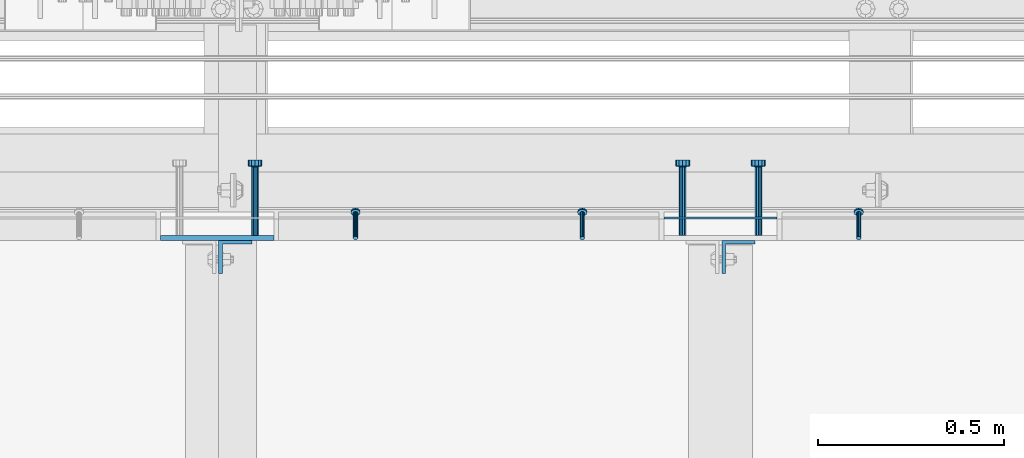
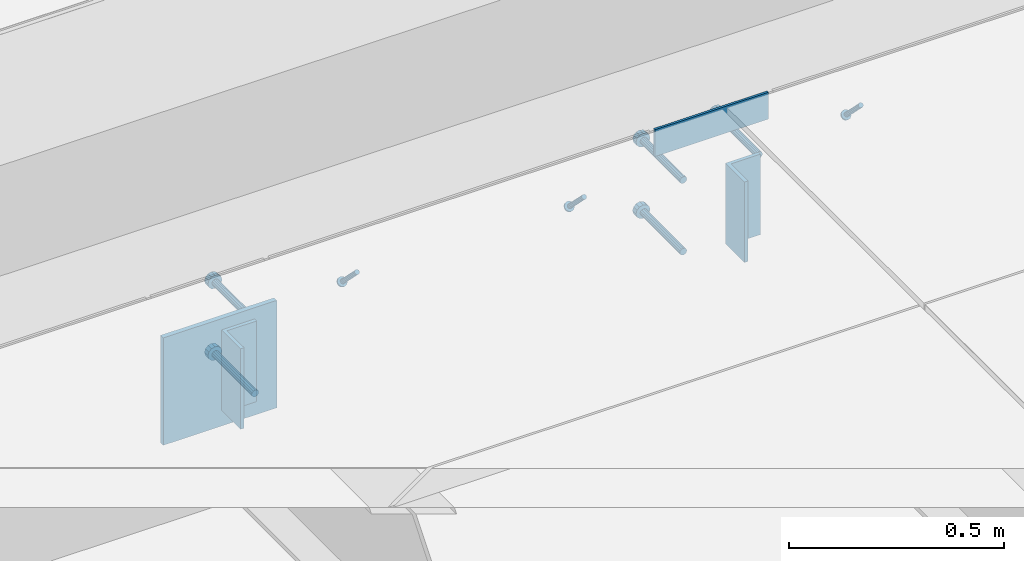
# One storey, part 2100 of 3843: 9 beams, 3 members, 6 elements without a shape of their own.
"""IFC2X3 building model written with IfcOpenShell, lengths in millimetres."""

from ifc_helpers import new_model, si_unit, frame, origin_with_axes, place, context, subcontext, project, spatial, faceted_brep, material, type_object, element, aggregate, save


model = new_model("IFC2X3")

# Units and contexts
model_context = context("Model", 3, precision=1e-05, world=origin_with_axes())
body_context = subcontext(model_context, "Body", "Model", "MODEL_VIEW")
ifc_project = project(units=[si_unit("LENGTHUNIT", "METRE", prefix="MILLI"), si_unit("AREAUNIT", "SQUARE_METRE"), si_unit("VOLUMEUNIT", "CUBIC_METRE"), si_unit("MASSUNIT", "GRAM", prefix="KILO"), si_unit("TIMEUNIT", "SECOND"), si_unit("PLANEANGLEUNIT", "RADIAN"), si_unit("SOLIDANGLEUNIT", "STERADIAN"), si_unit("THERMODYNAMICTEMPERATUREUNIT", "DEGREE_CELSIUS"), si_unit("LUMINOUSINTENSITYUNIT", "LUMEN")], contexts=[model_context])

# Site, building, storey
site_placement = place(None, origin_with_axes())
site = spatial("IfcSite", under=ifc_project, at=site_placement, CompositionType="ELEMENT")
building_placement = place(site_placement, origin_with_axes())
building = spatial("IfcBuilding", under=site, at=building_placement, Name="Undefined", CompositionType="ELEMENT")
storey_placement = place(building_placement, origin_with_axes())
storey = spatial("IfcBuildingStorey", under=building, at=storey_placement, Name="Undefined", CompositionType="ELEMENT", Elevation=0.0)

# Assembly, member
assembly_1_placement = place(storey_placement, origin_with_axes())
assembly_1 = element("IfcElementAssembly", 1, at=assembly_1_placement, inside=storey, Name="ANGLE", AssemblyPlace="NOTDEFINED", PredefinedType="RIGID_FRAME")
ifc_material_1 = material(Name="STEEL/A108")
member_type = type_object("IfcMemberType", PredefinedType="NOTDEFINED")
member_1_placement = place(assembly_1_placement, frame((47199.5402526855, 24930.0999970339, 30397.4500030518), z_axis=(-1.0, 0.0, 0.0), x_axis=(5.70000238222118e-08, 0.707106781186546, -0.707106781186546)))
member_1 = element("IfcMember", 2, at=member_1_placement, type_object=member_type, material=ifc_material_1, Name="HEADED STUD ANCHOR", context=body_context, shape_type="Brep", body=[
    faceted_brep([(7.27595761418343e-12, -3.18000006675175, 5.5), (0.0, -5.49999999998363, 3.1800000667572), (94.4879985803855, -5.50000000011278, 3.1800000667572), (94.4879985803782, -3.18000006687362, 5.5), (0.0, -6.3499999046162, 0.0), (94.4879985803855, -6.34999990474535, 0.0), (0.0, -5.49999999998363, -3.1800000667572), (94.4879985803855, -5.50000000011278, -3.1800000667572), (7.27595761418343e-12, -3.18000006675175, -5.5), (94.4879985803782, -3.18000006687362, -5.5), (7.27595761418343e-12, -1.81898940354586e-12, -6.34999990463257), (94.4879985803782, -1.20053300634027e-10, -6.34999990463257), (0.0, 3.18000006675175, -5.5), (94.4879985803709, 3.18000006663351, -5.5), (7.27595761418343e-12, 5.49999999998363, -3.1800000667572), (94.4879985803709, 5.49999999987267, -3.1800000667572), (7.27595761418343e-12, 6.3499999046162, 0.0), (94.4879985803673, 6.34999990450706, 0.0), (7.27595761418343e-12, 5.49999999998363, 3.1800000667572), (94.4879985803709, 5.49999999987267, 3.1800000667572), (0.0, 3.18000006675175, 5.5), (94.4879985803709, 3.18000006663351, 5.5), (7.27595761418343e-12, -1.81898940354586e-12, 6.34999990463257), (94.4879985803782, -1.20053300634027e-10, 6.34999990463257), (96.5199985498621, -10.9899997712273, 6.34999990463257), (96.5199985498548, -6.34000015270249, 10.9899997711182), (96.5199985498621, -12.6999998093743, 0.0), (96.5199985498621, -10.9899997712273, -6.34999990463257), (96.5199985498548, -6.34000015270249, -10.9899997711182), (96.5199985498475, -1.21872290037572e-10, -12.6899995803833), (96.5199985498402, 6.34000015245874, -10.9899997711182), (96.519998549833, 10.9899997709817, -6.34999990463257), (96.519998549833, 12.6999998091305, 0.0), (96.519998549833, 10.9899997709817, 6.34999990463257), (96.5199985498402, 6.34000015245874, 10.9899997711182), (96.5199985498475, -1.21872290037572e-10, 12.6899995803833), (101.599998473539, -10.9899997712328, 6.34999990463257), (101.599998473532, -6.34000015270976, 10.9899997711182), (101.599998473539, -12.6999998093797, 0.0), (101.599998473539, -10.9899997712328, -6.34999990463257), (101.599998473532, -6.34000015270976, -10.9899997711182), (101.599998473524, -1.29148247651756e-10, -12.6899995803833), (101.599998473517, 6.34000015245329, -10.9899997711182), (101.59999847351, 10.9899997709763, -6.34999990463257), (101.599998473503, 12.6999998091196, 0.0), (101.59999847351, 10.9899997709763, 6.34999990463257), (101.599998473517, 6.34000015245329, 10.9899997711182), (101.599998473524, -1.29148247651756e-10, 12.6899995803833)], [[[0, 1, 2, 3]], [[1, 4, 5, 2]], [[4, 6, 7, 5]], [[6, 8, 9, 7]], [[8, 10, 11, 9]], [[10, 12, 13, 11]], [[12, 14, 15, 13]], [[14, 16, 17, 15]], [[16, 18, 19, 17]], [[18, 20, 21, 19]], [[20, 22, 23, 21]], [[22, 0, 3, 23]], [[22, 20, 18, 16, 14, 12, 10, 8, 6, 4, 1, 0]], [[3, 2, 24, 25]], [[2, 5, 26, 24]], [[5, 7, 27, 26]], [[7, 9, 28, 27]], [[9, 11, 29, 28]], [[11, 13, 30, 29]], [[13, 15, 31, 30]], [[15, 17, 32, 31]], [[17, 19, 33, 32]], [[19, 21, 34, 33]], [[21, 23, 35, 34]], [[23, 3, 25, 35]], [[25, 24, 36, 37]], [[24, 26, 38, 36]], [[26, 27, 39, 38]], [[27, 28, 40, 39]], [[28, 29, 41, 40]], [[29, 30, 42, 41]], [[30, 31, 43, 42]], [[31, 32, 44, 43]], [[32, 33, 45, 44]], [[33, 34, 46, 45]], [[34, 35, 47, 46]], [[35, 25, 37, 47]], [[38, 39, 40, 41, 42, 43, 44, 45, 46, 47, 37, 36]]]),
])
aggregate(assembly_1, [member_1])

# Assembly, members
assembly_2_placement = place(storey_placement, origin_with_axes())
assembly_2 = element("IfcElementAssembly", 3, at=assembly_2_placement, inside=storey, Name="ANGLE", AssemblyPlace="NOTDEFINED", PredefinedType="RIGID_FRAME")
member_2_placement = place(assembly_2_placement, frame((45846.9902526855, 24930.0999969801, 30397.4500030518), z_axis=(-1.0, 0.0, 0.0), x_axis=(5.70000238222118e-08, 0.707106781186546, -0.707106781186546)))
member_2 = element("IfcMember", 4, at=member_2_placement, type_object=member_type, material=ifc_material_1, Name="HEADED STUD ANCHOR", context=body_context, shape_type="Brep", body=[
    faceted_brep([(7.27595761418343e-12, -3.18000006675175, 5.5), (0.0, -5.49999999998363, 3.1800000667572), (94.4879985803855, -5.50000000011278, 3.1800000667572), (94.4879985803782, -3.18000006687362, 5.5), (0.0, -6.3499999046162, 0.0), (94.4879985803855, -6.34999990474535, 0.0), (0.0, -5.49999999998363, -3.1800000667572), (94.4879985803855, -5.50000000011278, -3.1800000667572), (7.27595761418343e-12, -3.18000006675175, -5.5), (94.4879985803782, -3.18000006687362, -5.5), (7.27595761418343e-12, -1.81898940354586e-12, -6.34999990463257), (94.4879985803782, -1.20053300634027e-10, -6.34999990463257), (0.0, 3.18000006675175, -5.5), (94.4879985803709, 3.18000006663351, -5.5), (7.27595761418343e-12, 5.49999999998363, -3.1800000667572), (94.4879985803709, 5.49999999987267, -3.1800000667572), (7.27595761418343e-12, 6.3499999046162, 0.0), (94.4879985803673, 6.34999990450706, 0.0), (7.27595761418343e-12, 5.49999999998363, 3.1800000667572), (94.4879985803709, 5.49999999987267, 3.1800000667572), (0.0, 3.18000006675175, 5.5), (94.4879985803709, 3.18000006663351, 5.5), (7.27595761418343e-12, -1.81898940354586e-12, 6.34999990463257), (94.4879985803782, -1.20053300634027e-10, 6.34999990463257), (96.5199985498621, -10.9899997712273, 6.34999990463257), (96.5199985498548, -6.34000015270249, 10.9899997711182), (96.5199985498621, -12.6999998093743, 0.0), (96.5199985498621, -10.9899997712273, -6.34999990463257), (96.5199985498548, -6.34000015270249, -10.9899997711182), (96.5199985498475, -1.21872290037572e-10, -12.6899995803833), (96.5199985498402, 6.34000015245874, -10.9899997711182), (96.519998549833, 10.9899997709817, -6.34999990463257), (96.519998549833, 12.6999998091305, 0.0), (96.519998549833, 10.9899997709817, 6.34999990463257), (96.5199985498402, 6.34000015245874, 10.9899997711182), (96.5199985498475, -1.21872290037572e-10, 12.6899995803833), (101.599998473539, -10.9899997712328, 6.34999990463257), (101.599998473532, -6.34000015270976, 10.9899997711182), (101.599998473539, -12.6999998093797, 0.0), (101.599998473539, -10.9899997712328, -6.34999990463257), (101.599998473532, -6.34000015270976, -10.9899997711182), (101.599998473524, -1.29148247651756e-10, -12.6899995803833), (101.599998473517, 6.34000015245329, -10.9899997711182), (101.59999847351, 10.9899997709763, -6.34999990463257), (101.599998473503, 12.6999998091196, 0.0), (101.59999847351, 10.9899997709763, 6.34999990463257), (101.599998473517, 6.34000015245329, 10.9899997711182), (101.599998473524, -1.29148247651756e-10, 12.6899995803833)], [[[0, 1, 2, 3]], [[1, 4, 5, 2]], [[4, 6, 7, 5]], [[6, 8, 9, 7]], [[8, 10, 11, 9]], [[10, 12, 13, 11]], [[12, 14, 15, 13]], [[14, 16, 17, 15]], [[16, 18, 19, 17]], [[18, 20, 21, 19]], [[20, 22, 23, 21]], [[22, 0, 3, 23]], [[22, 20, 18, 16, 14, 12, 10, 8, 6, 4, 1, 0]], [[3, 2, 24, 25]], [[2, 5, 26, 24]], [[5, 7, 27, 26]], [[7, 9, 28, 27]], [[9, 11, 29, 28]], [[11, 13, 30, 29]], [[13, 15, 31, 30]], [[15, 17, 32, 31]], [[17, 19, 33, 32]], [[19, 21, 34, 33]], [[21, 23, 35, 34]], [[23, 3, 25, 35]], [[25, 24, 36, 37]], [[24, 26, 38, 36]], [[26, 27, 39, 38]], [[27, 28, 40, 39]], [[28, 29, 41, 40]], [[29, 30, 42, 41]], [[30, 31, 43, 42]], [[31, 32, 44, 43]], [[32, 33, 45, 44]], [[33, 34, 46, 45]], [[34, 35, 47, 46]], [[35, 25, 37, 47]], [[38, 39, 40, 41, 42, 43, 44, 45, 46, 47, 37, 36]]]),
])
member_3_placement = place(assembly_2_placement, frame((46456.5902526855, 24930.0999969801, 30397.4500030518), z_axis=(-1.0, 0.0, 0.0), x_axis=(5.70000238222118e-08, 0.707106781186546, -0.707106781186546)))
member_3 = element("IfcMember", 5, at=member_3_placement, type_object=member_type, material=ifc_material_1, Name="HEADED STUD ANCHOR", context=body_context, shape_type="Brep", body=[
    faceted_brep([(7.27595761418343e-12, -3.18000006675175, 5.5), (0.0, -5.49999999998363, 3.1800000667572), (94.4879985803855, -5.50000000011278, 3.1800000667572), (94.4879985803782, -3.18000006687362, 5.5), (0.0, -6.3499999046162, 0.0), (94.4879985803855, -6.34999990474535, 0.0), (0.0, -5.49999999998363, -3.1800000667572), (94.4879985803855, -5.50000000011278, -3.1800000667572), (7.27595761418343e-12, -3.18000006675175, -5.5), (94.4879985803782, -3.18000006687362, -5.5), (7.27595761418343e-12, -1.81898940354586e-12, -6.34999990463257), (94.4879985803782, -1.20053300634027e-10, -6.34999990463257), (0.0, 3.18000006675175, -5.5), (94.4879985803709, 3.18000006663351, -5.5), (7.27595761418343e-12, 5.49999999998363, -3.1800000667572), (94.4879985803709, 5.49999999987267, -3.1800000667572), (7.27595761418343e-12, 6.3499999046162, 0.0), (94.4879985803673, 6.34999990450706, 0.0), (7.27595761418343e-12, 5.49999999998363, 3.1800000667572), (94.4879985803709, 5.49999999987267, 3.1800000667572), (0.0, 3.18000006675175, 5.5), (94.4879985803709, 3.18000006663351, 5.5), (7.27595761418343e-12, -1.81898940354586e-12, 6.34999990463257), (94.4879985803782, -1.20053300634027e-10, 6.34999990463257), (96.5199985498621, -10.9899997712273, 6.34999990463257), (96.5199985498548, -6.34000015270249, 10.9899997711182), (96.5199985498621, -12.6999998093743, 0.0), (96.5199985498621, -10.9899997712273, -6.34999990463257), (96.5199985498548, -6.34000015270249, -10.9899997711182), (96.5199985498475, -1.21872290037572e-10, -12.6899995803833), (96.5199985498402, 6.34000015245874, -10.9899997711182), (96.519998549833, 10.9899997709817, -6.34999990463257), (96.519998549833, 12.6999998091305, 0.0), (96.519998549833, 10.9899997709817, 6.34999990463257), (96.5199985498402, 6.34000015245874, 10.9899997711182), (96.5199985498475, -1.21872290037572e-10, 12.6899995803833), (101.599998473539, -10.9899997712328, 6.34999990463257), (101.599998473532, -6.34000015270976, 10.9899997711182), (101.599998473539, -12.6999998093797, 0.0), (101.599998473539, -10.9899997712328, -6.34999990463257), (101.599998473532, -6.34000015270976, -10.9899997711182), (101.599998473524, -1.29148247651756e-10, -12.6899995803833), (101.599998473517, 6.34000015245329, -10.9899997711182), (101.59999847351, 10.9899997709763, -6.34999990463257), (101.599998473503, 12.6999998091196, 0.0), (101.59999847351, 10.9899997709763, 6.34999990463257), (101.599998473517, 6.34000015245329, 10.9899997711182), (101.599998473524, -1.29148247651756e-10, 12.6899995803833)], [[[0, 1, 2, 3]], [[1, 4, 5, 2]], [[4, 6, 7, 5]], [[6, 8, 9, 7]], [[8, 10, 11, 9]], [[10, 12, 13, 11]], [[12, 14, 15, 13]], [[14, 16, 17, 15]], [[16, 18, 19, 17]], [[18, 20, 21, 19]], [[20, 22, 23, 21]], [[22, 0, 3, 23]], [[22, 20, 18, 16, 14, 12, 10, 8, 6, 4, 1, 0]], [[3, 2, 24, 25]], [[2, 5, 26, 24]], [[5, 7, 27, 26]], [[7, 9, 28, 27]], [[9, 11, 29, 28]], [[11, 13, 30, 29]], [[13, 15, 31, 30]], [[15, 17, 32, 31]], [[17, 19, 33, 32]], [[19, 21, 34, 33]], [[21, 23, 35, 34]], [[23, 3, 25, 35]], [[25, 24, 36, 37]], [[24, 26, 38, 36]], [[26, 27, 39, 38]], [[27, 28, 40, 39]], [[28, 29, 41, 40]], [[29, 30, 42, 41]], [[30, 31, 43, 42]], [[31, 32, 44, 43]], [[32, 33, 45, 44]], [[33, 34, 46, 45]], [[34, 35, 47, 46]], [[35, 25, 37, 47]], [[38, 39, 40, 41, 42, 43, 44, 45, 46, 47, 37, 36]]]),
])
aggregate(assembly_2, [member_2, member_3])

# Assembly, beam
assembly_3_placement = place(storey_placement, origin_with_axes())
assembly_3 = element("IfcElementAssembly", 6, at=assembly_3_placement, inside=storey, Name="EMBED PLATE", AssemblyPlace="NOTDEFINED", PredefinedType="RIGID_FRAME")
ifc_material_2 = material(Name="STEEL/A36")
beam_type_1 = type_object("IfcBeamType", PredefinedType="NOTDEFINED")
beam_1_placement = place(assembly_3_placement, frame((46675.675, 24984.0749969483, 30441.9), z_axis=(0.0, 0.0, 1.0), x_axis=(1.0, 0.0, 0.0)))
beam_1 = element("IfcBeam", 7, at=beam_1_placement, type_object=beam_type_1, material=ifc_material_2, Name="PLATE", context=body_context, shape_type="Brep", body=[
    faceted_brep([(0.0, 3.17500000000291, -38.0999999999985), (0.0, 3.17500000000291, 38.0999999999985), (304.800000000003, 3.17499999999927, 38.0999999999985), (304.800000000003, 3.17499999999927, -38.0999999999985), (0.0, -3.17500000000291, 38.0999999999985), (304.800000000003, -3.17499999999927, 38.0999999999985), (0.0, -3.17500000000291, -38.0999999999985), (304.800000000003, -3.17499999999927, -38.0999999999985)], [[[0, 1, 2, 3]], [[1, 4, 5, 2]], [[4, 6, 7, 5]], [[6, 0, 3, 7]], [[5, 7, 3, 2]], [[6, 4, 1, 0]]]),
])

assembly_4_placement = place(storey_placement, origin_with_axes())
assembly_4 = element("IfcElementAssembly", 8, at=assembly_4_placement, inside=storey, Name="EMBED PLATE", AssemblyPlace="NOTDEFINED", PredefinedType="RIGID_FRAME")
beam_type_2 = type_object("IfcBeamType", PredefinedType="NOTDEFINED")
beam_2_placement = place(assembly_4_placement, frame((45475.525, 24930.1, 30397.45), z_axis=(1.0, 0.0, 0.0), x_axis=(0.0, 0.0, -1.0)))
beam_2 = element("IfcBeam", 9, at=beam_2_placement, type_object=beam_type_2, material=ifc_material_2, Name="EMBED PLATE", context=body_context, shape_type="Brep", body=[
    faceted_brep([(-1.0550138540566e-10, 6.34999999999854, -152.400000000664), (1.0550138540566e-10, 6.34999999999854, 152.400000000656), (304.799999999999, 6.34999999999854, 152.400000000001), (304.799999999999, 6.34999999999854, -152.400000000001), (1.0550138540566e-10, -6.34999999999854, 152.400000000656), (304.799999999999, -6.34999999999854, 152.400000000001), (-1.0550138540566e-10, -6.34999999999854, -152.400000000664), (304.799999999999, -6.34999999999854, -152.400000000001)], [[[0, 1, 2, 3]], [[1, 4, 5, 2]], [[4, 6, 7, 5]], [[6, 0, 3, 7]], [[5, 7, 3, 2]], [[6, 4, 1, 0]]]),
])

assembly_5_placement = place(storey_placement, origin_with_axes())
assembly_5 = element("IfcElementAssembly", 10, at=assembly_5_placement, inside=storey, Name="BEAM", AssemblyPlace="NOTDEFINED", PredefinedType="RIGID_FRAME")
beam_type_3 = type_object("IfcBeamType", Name="L3-1/2X3-1/2X3/8", PredefinedType="NOTDEFINED")
beam_3_placement = place(assembly_5_placement, frame((46876.49375, 24879.2999969483, 30365.7), z_axis=(1.0, 0.0, 0.0), x_axis=(0.0, 0.0, -1.0)))
beam_3 = element("IfcBeam", 11, at=beam_3_placement, type_object=beam_type_3, material=ifc_material_2, Name="ANGLE", ObjectType="L3-1/2X3-1/2X3/8", context=body_context, shape_type="Brep", body=[
    faceted_brep([(-3.63797880709171e-12, 44.4499999999971, -44.4500000000007), (-3.63797880709171e-12, 44.4499999999971, 44.4500000000007), (228.600000000006, 44.4499999999971, 44.4500000000007), (228.600000000006, 44.4499999999971, -44.4500000000007), (0.0, 34.9250000000029, 44.4500000000007), (228.600000000006, 34.9250000000029, 44.4500000000007), (0.0, 34.9250000000029, -34.9250000000029), (228.600000000006, 34.9250000000029, -34.9249999999993), (0.0, -44.4499999999971, -34.9249999999993), (228.600000000006, -44.4499999999971, -34.9249999999993), (3.63797880709171e-12, -44.4499999999971, -44.4500000000007), (228.600000000006, -44.4499999999971, -44.4500000000007)], [[[0, 1, 2, 3]], [[1, 4, 5, 2]], [[4, 6, 7, 5]], [[6, 8, 9, 7]], [[8, 10, 11, 9]], [[10, 0, 3, 11]], [[5, 7, 9, 11, 3, 2]], [[10, 8, 6, 4, 1, 0]]]),
])
aggregate(assembly_5, [beam_3])

assembly_6_placement = place(storey_placement, origin_with_axes())
assembly_6 = element("IfcElementAssembly", 12, at=assembly_6_placement, inside=storey, Name="BEAM", AssemblyPlace="NOTDEFINED", PredefinedType="RIGID_FRAME")
beam_4_placement = place(assembly_6_placement, frame((45523.94375, 24879.3, 30365.7), z_axis=(1.0, 0.0, 0.0), x_axis=(0.0, 0.0, -1.0)))
beam_4 = element("IfcBeam", 13, at=beam_4_placement, type_object=beam_type_3, material=ifc_material_2, Name="ANGLE", ObjectType="L3-1/2X3-1/2X3/8", context=body_context, shape_type="Brep", body=[
    faceted_brep([(-3.63797880709171e-12, 44.4499999999971, -44.4500000000007), (-3.63797880709171e-12, 44.4499999999971, 44.4500000000007), (228.600000000006, 44.4499999999971, 44.4500000000007), (228.600000000006, 44.4499999999971, -44.4500000000007), (0.0, 34.9250000000029, 44.4500000000007), (228.600000000006, 34.9250000000029, 44.4500000000007), (0.0, 34.9250000000029, -34.9250000000029), (228.600000000006, 34.9250000000029, -34.9249999999993), (0.0, -44.4499999999971, -34.9249999999993), (228.600000000006, -44.4499999999971, -34.9249999999993), (3.63797880709171e-12, -44.4499999999971, -44.4500000000007), (228.600000000006, -44.4499999999971, -44.4500000000007)], [[[0, 1, 2, 3]], [[1, 4, 5, 2]], [[4, 6, 7, 5]], [[6, 8, 9, 7]], [[8, 10, 11, 9]], [[10, 0, 3, 11]], [[5, 7, 9, 11, 3, 2]], [[10, 8, 6, 4, 1, 0]]]),
])
aggregate(assembly_6, [beam_4])

# Beam
beam_type_4 = type_object("IfcBeamType", PredefinedType="NOTDEFINED")
beam_5_placement = place(assembly_3_placement, frame((46726.475, 24936.4499969483, 30346.65), z_axis=(-1.0, 0.0, 0.0), x_axis=(0.0, 1.0, 0.0)))
beam_5 = element("IfcBeam", 14, at=beam_5_placement, type_object=beam_type_4, material=ifc_material_1, Name="HEADED STUD ANCHOR", context=body_context, shape_type="Brep", body=[
    faceted_brep([(0.0, -9.52000045776367, 0.0), (0.0, -8.25, -4.76000022888184), (184.912000000004, -8.25, -4.76000022888184), (184.912000000004, -9.52000045776367, 0.0), (0.0, -4.76000022888184, -8.25), (184.912000000004, -4.76000022888184, -8.25), (0.0, 0.0, -9.52000045776367), (184.912000000004, 0.0, -9.52000045776367), (0.0, 4.76000022888184, -8.25), (184.912000000004, 4.76000022888184, -8.25), (0.0, 8.25, -4.76000022888184), (184.912000000004, 8.25, -4.76000022888184), (0.0, 9.52000045776367, 0.0), (184.912000000004, 9.52000045776367, 0.0), (0.0, 8.25, 4.76000022888184), (184.912000000004, 8.25, 4.76000022888184), (0.0, 4.76000022888184, 8.25), (184.912000000004, 4.76000022888184, 8.25), (0.0, 0.0, 9.52000045776367), (184.912000000004, 0.0, 9.52000045776367), (0.0, -4.76000022888184, 8.25), (184.912000000004, -4.76000022888184, 8.25), (0.0, -8.25, 4.76000022888184), (184.912000000004, -8.25, 4.76000022888184), (186.944000000003, -16.5, -9.52000045776367), (186.944000000003, -19.0499992370605, 0.0), (186.944000000003, -9.52000045776367, -16.5), (186.944000000003, 0.0, -19.0499992370605), (186.944000000003, 9.52000045776367, -16.5), (186.944000000003, 16.5, -9.52000045776367), (186.944000000003, 19.0499992370605, 0.0), (186.944000000003, 16.5, 9.52000045776367), (186.944000000003, 9.52000045776367, 16.5), (186.944000000003, 0.0, 19.0499992370605), (186.944000000003, -9.52000045776367, 16.5), (186.944000000003, -16.5, 9.52000045776367), (203.199999999997, -16.5, -9.52000045776367), (203.199999999997, -19.0499992370605, 0.0), (203.199999999997, -9.52000045776367, -16.5), (203.199999999997, 0.0, -19.0499992370605), (203.199999999997, 9.52000045776367, -16.5), (203.199999999997, 16.5, -9.52000045776367), (203.199999999997, 19.0499992370605, 0.0), (203.199999999997, 16.5, 9.52000045776367), (203.199999999997, 9.52000045776367, 16.5), (203.199999999997, 0.0, 19.0499992370605), (203.199999999997, -9.52000045776367, 16.5), (203.199999999997, -16.5, 9.52000045776367)], [[[0, 1, 2, 3]], [[1, 4, 5, 2]], [[4, 6, 7, 5]], [[6, 8, 9, 7]], [[8, 10, 11, 9]], [[10, 12, 13, 11]], [[12, 14, 15, 13]], [[14, 16, 17, 15]], [[16, 18, 19, 17]], [[18, 20, 21, 19]], [[20, 22, 23, 21]], [[22, 0, 3, 23]], [[22, 20, 18, 16, 14, 12, 10, 8, 6, 4, 1, 0]], [[3, 2, 24, 25]], [[2, 5, 26, 24]], [[5, 7, 27, 26]], [[7, 9, 28, 27]], [[9, 11, 29, 28]], [[11, 13, 30, 29]], [[13, 15, 31, 30]], [[15, 17, 32, 31]], [[17, 19, 33, 32]], [[19, 21, 34, 33]], [[21, 23, 35, 34]], [[23, 3, 25, 35]], [[25, 24, 36, 37]], [[24, 26, 38, 36]], [[26, 27, 39, 38]], [[27, 28, 40, 39]], [[28, 29, 41, 40]], [[29, 30, 42, 41]], [[30, 31, 43, 42]], [[31, 32, 44, 43]], [[32, 33, 45, 44]], [[33, 34, 46, 45]], [[34, 35, 47, 46]], [[35, 25, 37, 47]], [[38, 39, 40, 41, 42, 43, 44, 45, 46, 47, 37, 36]]]),
])

beam_6_placement = place(assembly_3_placement, frame((46726.475, 24936.4499969483, 30143.45), z_axis=(-1.0, 0.0, 0.0), x_axis=(0.0, 1.0, 0.0)))
beam_6 = element("IfcBeam", 15, at=beam_6_placement, type_object=beam_type_4, material=ifc_material_1, Name="HEADED STUD ANCHOR", context=body_context, shape_type="Brep", body=[
    faceted_brep([(0.0, -9.52000045776367, 0.0), (0.0, -8.25, -4.76000022888184), (184.912000000004, -8.25, -4.76000022888184), (184.912000000004, -9.52000045776367, 0.0), (0.0, -4.76000022888184, -8.25), (184.912000000004, -4.76000022888184, -8.25), (0.0, 0.0, -9.52000045776367), (184.912000000004, 0.0, -9.52000045776367), (0.0, 4.76000022888184, -8.25), (184.912000000004, 4.76000022888184, -8.25), (0.0, 8.25, -4.76000022888184), (184.912000000004, 8.25, -4.76000022888184), (0.0, 9.52000045776367, 0.0), (184.912000000004, 9.52000045776367, 0.0), (0.0, 8.25, 4.76000022888184), (184.912000000004, 8.25, 4.76000022888184), (0.0, 4.76000022888184, 8.25), (184.912000000004, 4.76000022888184, 8.25), (0.0, 0.0, 9.52000045776367), (184.912000000004, 0.0, 9.52000045776367), (0.0, -4.76000022888184, 8.25), (184.912000000004, -4.76000022888184, 8.25), (0.0, -8.25, 4.76000022888184), (184.912000000004, -8.25, 4.76000022888184), (186.944000000003, -16.5, -9.52000045776367), (186.944000000003, -19.0499992370605, 0.0), (186.944000000003, -9.52000045776367, -16.5), (186.944000000003, 0.0, -19.0499992370605), (186.944000000003, 9.52000045776367, -16.5), (186.944000000003, 16.5, -9.52000045776367), (186.944000000003, 19.0499992370605, 0.0), (186.944000000003, 16.5, 9.52000045776367), (186.944000000003, 9.52000045776367, 16.5), (186.944000000003, 0.0, 19.0499992370605), (186.944000000003, -9.52000045776367, 16.5), (186.944000000003, -16.5, 9.52000045776367), (203.199999999997, -16.5, -9.52000045776367), (203.199999999997, -19.0499992370605, 0.0), (203.199999999997, -9.52000045776367, -16.5), (203.199999999997, 0.0, -19.0499992370605), (203.199999999997, 9.52000045776367, -16.5), (203.199999999997, 16.5, -9.52000045776367), (203.199999999997, 19.0499992370605, 0.0), (203.199999999997, 16.5, 9.52000045776367), (203.199999999997, 9.52000045776367, 16.5), (203.199999999997, 0.0, 19.0499992370605), (203.199999999997, -9.52000045776367, 16.5), (203.199999999997, -16.5, 9.52000045776367)], [[[0, 1, 2, 3]], [[1, 4, 5, 2]], [[4, 6, 7, 5]], [[6, 8, 9, 7]], [[8, 10, 11, 9]], [[10, 12, 13, 11]], [[12, 14, 15, 13]], [[14, 16, 17, 15]], [[16, 18, 19, 17]], [[18, 20, 21, 19]], [[20, 22, 23, 21]], [[22, 0, 3, 23]], [[22, 20, 18, 16, 14, 12, 10, 8, 6, 4, 1, 0]], [[3, 2, 24, 25]], [[2, 5, 26, 24]], [[5, 7, 27, 26]], [[7, 9, 28, 27]], [[9, 11, 29, 28]], [[11, 13, 30, 29]], [[13, 15, 31, 30]], [[15, 17, 32, 31]], [[17, 19, 33, 32]], [[19, 21, 34, 33]], [[21, 23, 35, 34]], [[23, 3, 25, 35]], [[25, 24, 36, 37]], [[24, 26, 38, 36]], [[26, 27, 39, 38]], [[27, 28, 40, 39]], [[28, 29, 41, 40]], [[29, 30, 42, 41]], [[30, 31, 43, 42]], [[31, 32, 44, 43]], [[32, 33, 45, 44]], [[33, 34, 46, 45]], [[34, 35, 47, 46]], [[35, 25, 37, 47]], [[38, 39, 40, 41, 42, 43, 44, 45, 46, 47, 37, 36]]]),
])

beam_7_placement = place(assembly_3_placement, frame((46929.675, 24936.4499969483, 30346.65), z_axis=(-1.0, 0.0, 0.0), x_axis=(0.0, 1.0, 0.0)))
beam_7 = element("IfcBeam", 16, at=beam_7_placement, type_object=beam_type_4, material=ifc_material_2, Name="PLATE", context=body_context, shape_type="Brep", body=[
    faceted_brep([(0.0, -9.52000045776367, 0.0), (0.0, -8.25, -4.76000022888184), (184.912000000004, -8.25, -4.76000022888184), (184.912000000004, -9.52000045776367, 0.0), (0.0, -4.76000022888184, -8.25), (184.912000000004, -4.76000022888184, -8.25), (0.0, 0.0, -9.52000045776367), (184.912000000004, 0.0, -9.52000045776367), (0.0, 4.76000022888184, -8.25), (184.912000000004, 4.76000022888184, -8.25), (0.0, 8.25, -4.76000022888184), (184.912000000004, 8.25, -4.76000022888184), (0.0, 9.52000045776367, 0.0), (184.912000000004, 9.52000045776367, 0.0), (0.0, 8.25, 4.76000022888184), (184.912000000004, 8.25, 4.76000022888184), (0.0, 4.76000022888184, 8.25), (184.912000000004, 4.76000022888184, 8.25), (0.0, 0.0, 9.52000045776367), (184.912000000004, 0.0, 9.52000045776367), (0.0, -4.76000022888184, 8.25), (184.912000000004, -4.76000022888184, 8.25), (0.0, -8.25, 4.76000022888184), (184.912000000004, -8.25, 4.76000022888184), (186.944000000003, -16.5, -9.52000045776367), (186.944000000003, -19.0499992370605, 0.0), (186.944000000003, -9.52000045776367, -16.5), (186.944000000003, 0.0, -19.0499992370605), (186.944000000003, 9.52000045776367, -16.5), (186.944000000003, 16.5, -9.52000045776367), (186.944000000003, 19.0499992370605, 0.0), (186.944000000003, 16.5, 9.52000045776367), (186.944000000003, 9.52000045776367, 16.5), (186.944000000003, 0.0, 19.0499992370605), (186.944000000003, -9.52000045776367, 16.5), (186.944000000003, -16.5, 9.52000045776367), (203.199999999997, -16.5, -9.52000045776367), (203.199999999997, -19.0499992370605, 0.0), (203.199999999997, -9.52000045776367, -16.5), (203.199999999997, 0.0, -19.0499992370605), (203.199999999997, 9.52000045776367, -16.5), (203.199999999997, 16.5, -9.52000045776367), (203.199999999997, 19.0499992370605, 0.0), (203.199999999997, 16.5, 9.52000045776367), (203.199999999997, 9.52000045776367, 16.5), (203.199999999997, 0.0, 19.0499992370605), (203.199999999997, -9.52000045776367, 16.5), (203.199999999997, -16.5, 9.52000045776367)], [[[0, 1, 2, 3]], [[1, 4, 5, 2]], [[4, 6, 7, 5]], [[6, 8, 9, 7]], [[8, 10, 11, 9]], [[10, 12, 13, 11]], [[12, 14, 15, 13]], [[14, 16, 17, 15]], [[16, 18, 19, 17]], [[18, 20, 21, 19]], [[20, 22, 23, 21]], [[22, 0, 3, 23]], [[22, 20, 18, 16, 14, 12, 10, 8, 6, 4, 1, 0]], [[3, 2, 24, 25]], [[2, 5, 26, 24]], [[5, 7, 27, 26]], [[7, 9, 28, 27]], [[9, 11, 29, 28]], [[11, 13, 30, 29]], [[13, 15, 31, 30]], [[15, 17, 32, 31]], [[17, 19, 33, 32]], [[19, 21, 34, 33]], [[21, 23, 35, 34]], [[23, 3, 25, 35]], [[25, 24, 36, 37]], [[24, 26, 38, 36]], [[26, 27, 39, 38]], [[27, 28, 40, 39]], [[28, 29, 41, 40]], [[29, 30, 42, 41]], [[30, 31, 43, 42]], [[31, 32, 44, 43]], [[32, 33, 45, 44]], [[33, 34, 46, 45]], [[34, 35, 47, 46]], [[35, 25, 37, 47]], [[38, 39, 40, 41, 42, 43, 44, 45, 46, 47, 37, 36]]]),
])

aggregate(assembly_3, [beam_1, beam_5, beam_6, beam_7])

beam_8_placement = place(assembly_4_placement, frame((45577.125, 24936.45, 30346.65), z_axis=(-1.0, 0.0, 0.0), x_axis=(0.0, 1.0, 0.0)))
beam_8 = element("IfcBeam", 17, at=beam_8_placement, type_object=beam_type_4, material=ifc_material_2, Name="PLATE", context=body_context, shape_type="Brep", body=[
    faceted_brep([(0.0, -9.52000045776367, 0.0), (0.0, -8.25, -4.76000022888184), (184.912000000004, -8.25, -4.76000022888184), (184.912000000004, -9.52000045776367, 0.0), (0.0, -4.76000022888184, -8.25), (184.912000000004, -4.76000022888184, -8.25), (0.0, 0.0, -9.52000045776367), (184.912000000004, 0.0, -9.52000045776367), (0.0, 4.76000022888184, -8.25), (184.912000000004, 4.76000022888184, -8.25), (0.0, 8.25, -4.76000022888184), (184.912000000004, 8.25, -4.76000022888184), (0.0, 9.52000045776367, 0.0), (184.912000000004, 9.52000045776367, 0.0), (0.0, 8.25, 4.76000022888184), (184.912000000004, 8.25, 4.76000022888184), (0.0, 4.76000022888184, 8.25), (184.912000000004, 4.76000022888184, 8.25), (0.0, 0.0, 9.52000045776367), (184.912000000004, 0.0, 9.52000045776367), (0.0, -4.76000022888184, 8.25), (184.912000000004, -4.76000022888184, 8.25), (0.0, -8.25, 4.76000022888184), (184.912000000004, -8.25, 4.76000022888184), (186.944000000003, -16.5, -9.52000045776367), (186.944000000003, -19.0499992370605, 0.0), (186.944000000003, -9.52000045776367, -16.5), (186.944000000003, 0.0, -19.0499992370605), (186.944000000003, 9.52000045776367, -16.5), (186.944000000003, 16.5, -9.52000045776367), (186.944000000003, 19.0499992370605, 0.0), (186.944000000003, 16.5, 9.52000045776367), (186.944000000003, 9.52000045776367, 16.5), (186.944000000003, 0.0, 19.0499992370605), (186.944000000003, -9.52000045776367, 16.5), (186.944000000003, -16.5, 9.52000045776367), (203.199999999997, -16.5, -9.52000045776367), (203.199999999997, -19.0499992370605, 0.0), (203.199999999997, -9.52000045776367, -16.5), (203.199999999997, 0.0, -19.0499992370605), (203.199999999997, 9.52000045776367, -16.5), (203.199999999997, 16.5, -9.52000045776367), (203.199999999997, 19.0499992370605, 0.0), (203.199999999997, 16.5, 9.52000045776367), (203.199999999997, 9.52000045776367, 16.5), (203.199999999997, 0.0, 19.0499992370605), (203.199999999997, -9.52000045776367, 16.5), (203.199999999997, -16.5, 9.52000045776367)], [[[0, 1, 2, 3]], [[1, 4, 5, 2]], [[4, 6, 7, 5]], [[6, 8, 9, 7]], [[8, 10, 11, 9]], [[10, 12, 13, 11]], [[12, 14, 15, 13]], [[14, 16, 17, 15]], [[16, 18, 19, 17]], [[18, 20, 21, 19]], [[20, 22, 23, 21]], [[22, 0, 3, 23]], [[22, 20, 18, 16, 14, 12, 10, 8, 6, 4, 1, 0]], [[3, 2, 24, 25]], [[2, 5, 26, 24]], [[5, 7, 27, 26]], [[7, 9, 28, 27]], [[9, 11, 29, 28]], [[11, 13, 30, 29]], [[13, 15, 31, 30]], [[15, 17, 32, 31]], [[17, 19, 33, 32]], [[19, 21, 34, 33]], [[21, 23, 35, 34]], [[23, 3, 25, 35]], [[25, 24, 36, 37]], [[24, 26, 38, 36]], [[26, 27, 39, 38]], [[27, 28, 40, 39]], [[28, 29, 41, 40]], [[29, 30, 42, 41]], [[30, 31, 43, 42]], [[31, 32, 44, 43]], [[32, 33, 45, 44]], [[33, 34, 46, 45]], [[34, 35, 47, 46]], [[35, 25, 37, 47]], [[38, 39, 40, 41, 42, 43, 44, 45, 46, 47, 37, 36]]]),
])

beam_9_placement = place(assembly_4_placement, frame((45577.125, 24936.45, 30143.45), z_axis=(-1.0, 0.0, 0.0), x_axis=(0.0, 1.0, 0.0)))
beam_9 = element("IfcBeam", 18, at=beam_9_placement, type_object=beam_type_4, material=ifc_material_1, Name="HEADED STUD ANCHOR", context=body_context, shape_type="Brep", body=[
    faceted_brep([(0.0, -9.52000045776367, 0.0), (0.0, -8.25, -4.76000022888184), (184.912000000004, -8.25, -4.76000022888184), (184.912000000004, -9.52000045776367, 0.0), (0.0, -4.76000022888184, -8.25), (184.912000000004, -4.76000022888184, -8.25), (0.0, 0.0, -9.52000045776367), (184.912000000004, 0.0, -9.52000045776367), (0.0, 4.76000022888184, -8.25), (184.912000000004, 4.76000022888184, -8.25), (0.0, 8.25, -4.76000022888184), (184.912000000004, 8.25, -4.76000022888184), (0.0, 9.52000045776367, 0.0), (184.912000000004, 9.52000045776367, 0.0), (0.0, 8.25, 4.76000022888184), (184.912000000004, 8.25, 4.76000022888184), (0.0, 4.76000022888184, 8.25), (184.912000000004, 4.76000022888184, 8.25), (0.0, 0.0, 9.52000045776367), (184.912000000004, 0.0, 9.52000045776367), (0.0, -4.76000022888184, 8.25), (184.912000000004, -4.76000022888184, 8.25), (0.0, -8.25, 4.76000022888184), (184.912000000004, -8.25, 4.76000022888184), (186.944000000003, -16.5, -9.52000045776367), (186.944000000003, -19.0499992370605, 0.0), (186.944000000003, -9.52000045776367, -16.5), (186.944000000003, 0.0, -19.0499992370605), (186.944000000003, 9.52000045776367, -16.5), (186.944000000003, 16.5, -9.52000045776367), (186.944000000003, 19.0499992370605, 0.0), (186.944000000003, 16.5, 9.52000045776367), (186.944000000003, 9.52000045776367, 16.5), (186.944000000003, 0.0, 19.0499992370605), (186.944000000003, -9.52000045776367, 16.5), (186.944000000003, -16.5, 9.52000045776367), (203.199999999997, -16.5, -9.52000045776367), (203.199999999997, -19.0499992370605, 0.0), (203.199999999997, -9.52000045776367, -16.5), (203.199999999997, 0.0, -19.0499992370605), (203.199999999997, 9.52000045776367, -16.5), (203.199999999997, 16.5, -9.52000045776367), (203.199999999997, 19.0499992370605, 0.0), (203.199999999997, 16.5, 9.52000045776367), (203.199999999997, 9.52000045776367, 16.5), (203.199999999997, 0.0, 19.0499992370605), (203.199999999997, -9.52000045776367, 16.5), (203.199999999997, -16.5, 9.52000045776367)], [[[0, 1, 2, 3]], [[1, 4, 5, 2]], [[4, 6, 7, 5]], [[6, 8, 9, 7]], [[8, 10, 11, 9]], [[10, 12, 13, 11]], [[12, 14, 15, 13]], [[14, 16, 17, 15]], [[16, 18, 19, 17]], [[18, 20, 21, 19]], [[20, 22, 23, 21]], [[22, 0, 3, 23]], [[22, 20, 18, 16, 14, 12, 10, 8, 6, 4, 1, 0]], [[3, 2, 24, 25]], [[2, 5, 26, 24]], [[5, 7, 27, 26]], [[7, 9, 28, 27]], [[9, 11, 29, 28]], [[11, 13, 30, 29]], [[13, 15, 31, 30]], [[15, 17, 32, 31]], [[17, 19, 33, 32]], [[19, 21, 34, 33]], [[21, 23, 35, 34]], [[23, 3, 25, 35]], [[25, 24, 36, 37]], [[24, 26, 38, 36]], [[26, 27, 39, 38]], [[27, 28, 40, 39]], [[28, 29, 41, 40]], [[29, 30, 42, 41]], [[30, 31, 43, 42]], [[31, 32, 44, 43]], [[32, 33, 45, 44]], [[33, 34, 46, 45]], [[34, 35, 47, 46]], [[35, 25, 37, 47]], [[38, 39, 40, 41, 42, 43, 44, 45, 46, 47, 37, 36]]]),
])

aggregate(assembly_4, [beam_8, beam_9, beam_2])

save(model, "model.ifc")
